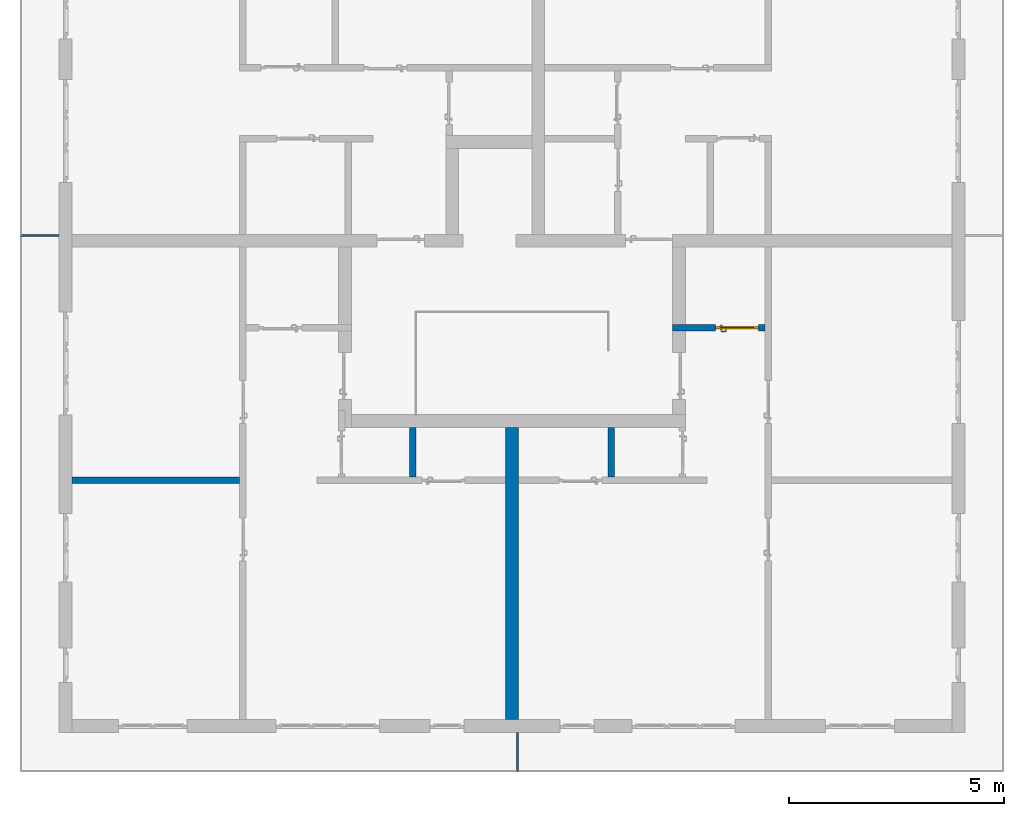
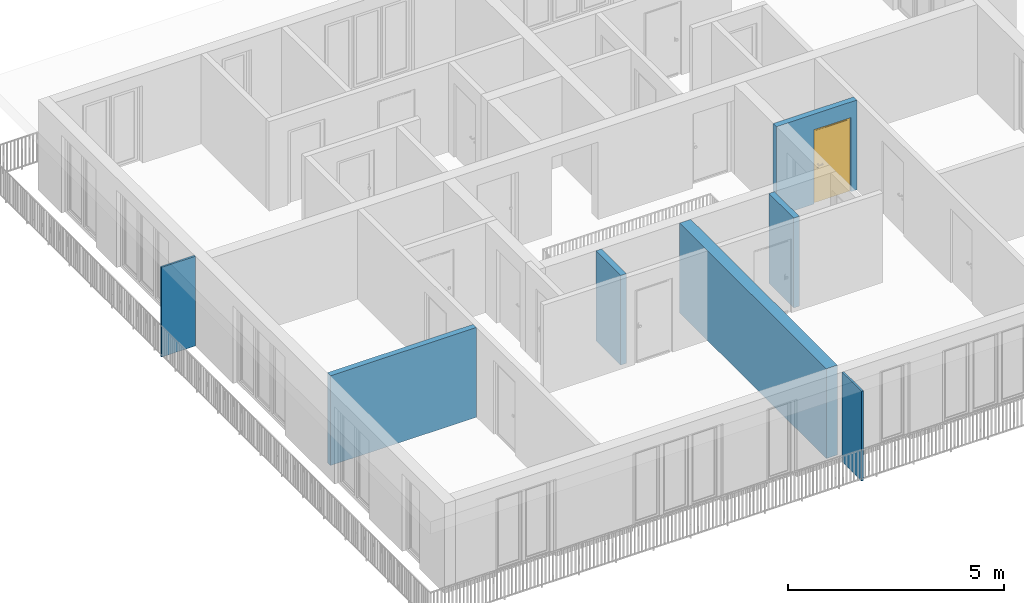
# One storey, part 7 of 54: 7 walls, 1 door, 1 opening.
"""IFC4 building model written with IfcOpenShell, lengths in metres."""

from ifc_helpers import new_model, entity, si_unit, converted_unit, derived_unit, direction, frame, origin_with_axes, place, context, subcontext, project, spatial, polygons, source, transform, mapped, material, type_object, element, fill, save


model = new_model("IFC4")

# Units and contexts
model_context = context("Model", 3, precision=1e-05, world=origin_with_axes(), true_north=direction((0.0, 1.0)))
body_context = subcontext(model_context, "Body", "Model", "MODEL_VIEW")
ifc_project = project(units=[si_unit("LENGTHUNIT", "METRE"), si_unit("AREAUNIT", "SQUARE_METRE"), si_unit("VOLUMEUNIT", "CUBIC_METRE"), converted_unit("PLANEANGLEUNIT", "DEGREE", entity("IfcPlaneAngleMeasure", 0.0174532925199), si_unit("PLANEANGLEUNIT", "RADIAN"), dimensions=[0, 0, 0, 0, 0, 0, 0]), converted_unit("TIMEUNIT", "Year", entity("IfcTimeMeasure", 31556926.0), si_unit("TIMEUNIT", "SECOND"), dimensions=[0, 0, 1, 0, 0, 0, 0]), si_unit("MASSUNIT", "GRAM", prefix="KILO"), si_unit("THERMODYNAMICTEMPERATUREUNIT", "DEGREE_CELSIUS"), si_unit("LUMINOUSINTENSITYUNIT", "LUMEN"), si_unit("ENERGYUNIT", "JOULE", prefix="MEGA"), derived_unit("THERMALCONDUCTANCEUNIT", [(si_unit("POWERUNIT", "WATT"), 1), (si_unit("LENGTHUNIT", "METRE"), -1), (si_unit("THERMODYNAMICTEMPERATUREUNIT", "KELVIN"), -1)]), derived_unit("SPECIFICHEATCAPACITYUNIT", [(si_unit("ENERGYUNIT", "JOULE"), 1), (si_unit("MASSUNIT", "GRAM", prefix="KILO"), -1), (si_unit("THERMODYNAMICTEMPERATUREUNIT", "KELVIN"), -1)]), derived_unit("MASSDENSITYUNIT", [(si_unit("MASSUNIT", "GRAM", prefix="KILO"), 1), (si_unit("VOLUMEUNIT", "CUBIC_METRE"), -1)])], contexts=[model_context])

# Site, building, storey
site_placement = place(None, origin_with_axes())
site = spatial("IfcSite", under=ifc_project, at=site_placement, CompositionType="ELEMENT")
building_placement = place(site_placement, origin_with_axes())
building = spatial("IfcBuilding", under=site, at=building_placement, CompositionType="ELEMENT")
storey_placement = place(building_placement, frame((0.0, 0.0, 9.18), z_axis=(0.0, 0.0, 1.0), x_axis=(1.0, 0.0, 0.0)))
storey = spatial("IfcBuildingStorey", under=building, at=storey_placement, Name="3. Geschoss", CompositionType="ELEMENT", Elevation=9.18)

# Walls
ifc_material_1 = material()
wall_type_1 = type_object("IfcWallType", Name="300", PredefinedType="NOTDEFINED")
wall_1_placement = place(storey_placement, frame((-1.2021993804, -2.52881223104, 0.0), z_axis=(0.0, 0.0, 1.0), x_axis=(0.0, -1.0, 0.0)))
element("IfcWall", 1, at=wall_1_placement, inside=storey, type_object=wall_type_1, material=ifc_material_1, Name="Wand-001", PredefinedType="NOTDEFINED", context=body_context, shape_type="Tessellation", body=[
    polygons([(0.3, -0.15, 0.0), (0.3, -0.15, 2.54), (0.3, 0.15, 2.54), (0.3, 0.15, 0.0), (7.1, -0.15, 0.0), (7.1, -0.15, 2.54), (7.1, 0.15, 2.54), (7.1, 0.15, 0.0)], [[[1, 2, 3, 4]], [[5, 6, 2, 1]], [[6, 7, 3, 2]], [[4, 3, 7, 8]], [[1, 4, 8, 5]], [[8, 7, 6, 5]]], closed=True),
])
wall_type_2 = type_object("IfcWallType", Name="150", PredefinedType="NOTDEFINED")
wall_2_placement = place(storey_placement, frame((-11.7421993804, -4.12881223104, 0.0), z_axis=(0.0, 0.0, 1.0), x_axis=(1.0, 0.0, 0.0)))
element("IfcWall", 2, at=wall_2_placement, inside=storey, type_object=wall_type_2, material=ifc_material_1, Name="Wand-004", PredefinedType="NOTDEFINED", context=body_context, shape_type="Tessellation", body=[
    polygons([(0.3, 0.15, 0.0), (0.3, 0.15, 2.54), (4.2, 0.15, 2.54), (4.2, 0.15, 0.0), (0.3, 0.0, 0.0), (0.3, 0.0, 2.54), (4.2, 0.0, 2.54), (4.2, 0.0, 0.0)], [[[1, 2, 3, 4]], [[5, 6, 2, 1]], [[6, 7, 3, 2]], [[4, 3, 7, 8]], [[1, 4, 8, 5]], [[8, 7, 6, 5]]], closed=True),
])
wall_3_placement = place(storey_placement, frame((-3.5921993804, -4.12881223104, 0.0), z_axis=(0.0, 0.0, 1.0), x_axis=(0.0, 1.0, 0.0)))
element("IfcWall", 3, at=wall_3_placement, inside=storey, type_object=wall_type_2, material=ifc_material_1, Name="Wand-002", PredefinedType="NOTDEFINED", context=body_context, shape_type="Tessellation", body=[
    polygons([(1.3, 0.0, 0.0), (1.3, 0.0, 2.54), (1.3, -0.15, 2.54), (1.3, -0.15, 0.0), (0.15, 0.0, 0.0), (0.15, 0.0, 2.54), (0.15, -0.15, 2.54), (0.15, -0.15, 0.0)], [[[1, 2, 3, 4]], [[5, 6, 2, 1]], [[6, 7, 3, 2]], [[4, 3, 7, 8]], [[5, 1, 4, 8]], [[8, 7, 6, 5]]], closed=True),
])
wall_4_placement = place(storey_placement, frame((1.1878006196, -4.12881223104, 0.0), z_axis=(0.0, 0.0, 1.0), x_axis=(0.0, 1.0, 0.0)))
element("IfcWall", 4, at=wall_4_placement, inside=storey, type_object=wall_type_2, material=ifc_material_1, Name="Wand-002", PredefinedType="NOTDEFINED", context=body_context, shape_type="Tessellation", body=[
    polygons([(1.3, 0.15, 0.0), (1.3, 0.15, 2.54), (1.3, 0.0, 2.54), (1.3, 0.0, 0.0), (0.15, 0.15, 0.0), (0.15, 0.15, 2.54), (0.15, 0.0, 2.54), (0.15, 0.0, 0.0)], [[[1, 2, 3, 4]], [[5, 6, 2, 1]], [[6, 7, 3, 2]], [[4, 3, 7, 8]], [[5, 1, 4, 8]], [[8, 7, 6, 5]]], closed=True),
])

# Wall, opening, door
wall_5_placement = place(storey_placement, frame((2.5378006196, -0.428812231043, 0.0), z_axis=(0.0, 0.0, 1.0), x_axis=(1.0, 0.0, 0.0)))
wall_5 = element("IfcWall", 5, at=wall_5_placement, inside=storey, type_object=wall_type_2, material=ifc_material_1, Name="Wand-002", PredefinedType="NOTDEFINED", context=body_context, shape_type="Tessellation", body=[
    polygons([(2.0, -0.05, 0.0), (2.0, -0.15, 0.0), (2.0, -0.15, 2.1), (2.0, 0.0, 2.1), (2.0, 0.0, 0.0), (2.15, 0.0, 0.0), (2.15, -0.15, 0.0), (2.15, -0.15, 2.54), (0.0, -0.15, 2.54), (0.0, -0.15, 0.0), (1.0, -0.15, 0.0), (1.0, -0.15, 2.1), (1.0, 0.0, 2.1), (1.0, 0.0, 0.0), (0.0, 0.0, 0.0), (0.0, 0.0, 2.54), (2.15, 0.0, 2.54), (1.0, -0.05, 0.0)], [[[1, 2, 3, 4, 5]], [[2, 1, 5, 6, 7]], [[3, 2, 7, 8, 9, 10, 11, 12]], [[4, 3, 12, 13]], [[6, 5, 4, 13, 14, 15, 16, 17]], [[8, 7, 6, 17]], [[17, 16, 9, 8]], [[16, 15, 10, 9]], [[18, 11, 10, 15, 14]], [[12, 11, 18, 14, 13]]], closed=True),
])
opening_placement = place(wall_5_placement, frame((1.5, 0.0, 0.0), z_axis=(0.0, 0.0, 1.0), x_axis=(1.0, 0.0, 0.0)))
opening = element("IfcOpeningElement", 6, at=opening_placement, cuts=wall_5, context=body_context, identifier="Reference", shape_type="Tessellation", body=[
    polygons([(-0.5, -0.05, 0.0), (-0.5, -0.05, 2.1), (-0.5, 0.001, 2.1), (-0.5, 0.001, 0.0), (-0.5, -0.151, 0.0), (-0.5, -0.151, 2.1), (0.5, -0.05, 2.1), (0.5, 0.001, 2.1), (0.5, -0.151, 2.1), (0.5, 0.001, 0.0), (0.5, -0.05, 0.0), (0.5, -0.151, 0.0)], [[[1, 2, 3, 4]], [[2, 1, 5, 6]], [[7, 8, 3, 2, 6, 9]], [[8, 10, 4, 3]], [[1, 4, 10, 11, 12, 5]], [[6, 5, 12, 9]], [[7, 11, 10, 8]], [[11, 7, 9, 12]]], closed=True),
])
door_type = type_object("IfcDoorType", Name="Eingang 01 1-Fl 26", OperationType="SINGLE_SWING_LEFT", PredefinedType="DOOR")
shared_shape = source(origin_with_axes(), body_context, "Body", "Tessellation", [
    polygons([(-0.5, -0.05, 0.0), (-0.5, -0.05, 2.1), (-0.5, -0.03, 2.1), (-0.5, -0.03, 0.0), (-0.4, -0.05, 0.0), (-0.4, -0.05, 2.0), (-0.1301, -0.05, 2.0), (-0.0001, -0.05, 2.0), (0.4, -0.05, 2.0), (0.4, -0.05, 0.0), (0.5, -0.05, 0.0), (0.5, -0.05, 2.1), (0.5, -0.03, 2.1), (0.5, -0.03, 0.0), (0.4, -0.03, 0.0), (0.4, -0.03, 2.0), (-0.0001, -0.03, 2.0), (-0.1301, -0.03, 2.0), (-0.4, -0.03, 2.0), (-0.4, -0.03, 0.0)], [[[1, 2, 3, 4]], [[1, 5, 6, 7, 8, 9, 10, 11, 12, 2]], [[2, 12, 13, 3]], [[4, 3, 13, 14, 15, 16, 17, 18, 19, 20]], [[5, 1, 4, 20]], [[6, 5, 20, 19]], [[7, 6, 19, 18]], [[8, 7, 18, 17]], [[9, 8, 17, 16]], [[10, 9, 16, 15]], [[11, 10, 15, 14]], [[12, 11, 14, 13]]], closed=True),
    polygons([(-0.5, -0.03, 0.0), (-0.5, -0.03, 2.1), (-0.5, 0.0, 2.1), (-0.5, 0.0, 0.0), (-0.43, -0.03, 0.0), (-0.43, -0.03, 2.03), (-0.1001, -0.03, 2.03), (-0.0301, -0.03, 2.03), (0.43, -0.03, 2.03), (0.43, -0.03, 0.0), (0.5, -0.03, 0.0), (0.5, -0.03, 2.1), (0.5, 0.0, 2.1), (0.5, 0.0, 0.0), (0.43, 0.0, 0.0), (0.43, 0.0, 2.03), (-0.0301, 0.0, 2.03), (-0.1001, 0.0, 2.03), (-0.43, 0.0, 2.03), (-0.43, 0.0, 0.0)], [[[1, 2, 3, 4]], [[1, 5, 6, 7, 8, 9, 10, 11, 12, 2]], [[2, 12, 13, 3]], [[4, 3, 13, 14, 15, 16, 17, 18, 19, 20]], [[5, 1, 4, 20]], [[6, 5, 20, 19]], [[7, 6, 19, 18]], [[8, 7, 18, 17]], [[9, 8, 17, 16]], [[10, 9, 16, 15]], [[11, 10, 15, 14]], [[12, 11, 14, 13]]], closed=True),
    polygons([(-0.43, 0.01, 0.0), (-0.43, 0.01, 2.03), (0.43, 0.01, 2.03), (0.43, 0.01, 0.0), (-0.43, -0.03, 0.0), (-0.43, -0.03, 2.03), (0.43, -0.03, 2.03), (0.43, -0.03, 0.0)], [[[1, 2, 3, 4]], [[1, 5, 6, 2]], [[2, 6, 7, 3]], [[3, 7, 8, 4]], [[4, 8, 5, 1]], [[8, 7, 6, 5]]], closed=True),
    polygons([(-0.395, -0.05, 0.0), (0.395, -0.05, 0.0), (0.395, -0.05, 0.05), (-0.395, -0.05, 0.05), (-0.395, -0.03, 0.0), (0.395, -0.03, 0.0), (0.395, -0.03, 0.07), (0.395, -0.035, 0.07), (-0.395, -0.035, 0.07), (-0.395, -0.03, 0.07)], [[[1, 2, 3, 4]], [[5, 6, 2, 1]], [[2, 6, 7, 8, 3]], [[4, 3, 8, 9]], [[1, 4, 9, 10, 5]], [[10, 7, 6, 5]], [[9, 8, 7, 10]]], closed=True),
    polygons([(0.3835, 0.02, 1.0733826859), (0.37, 0.02, 1.077), (0.37, 0.0199, 1.077), (0.3835, 0.0199, 1.0733826859), (0.393382685902, 0.02, 1.0635), (0.397, 0.02, 1.05), (0.393382685902, 0.02, 1.0365), (0.3835, 0.02, 1.0266173141), (0.37, 0.02, 1.023), (0.3565, 0.02, 1.0266173141), (0.346617314098, 0.02, 1.0365), (0.343, 0.02, 1.05), (0.346617314098, 0.02, 1.0635), (0.3565, 0.02, 1.0733826859), (0.3565, 0.0199, 1.0733826859), (0.37, 0.0101, 1.077), (0.3835, 0.0101, 1.0733826859), (0.393382685902, 0.0199, 1.0635), (0.397, 0.0199, 1.05), (0.393382685902, 0.0199, 1.0365), (0.3835, 0.0199, 1.0266173141), (0.37, 0.0199, 1.023), (0.3565, 0.0199, 1.0266173141), (0.346617314098, 0.0199, 1.0365), (0.343, 0.0199, 1.05), (0.346617314098, 0.0199, 1.0635), (0.3565, 0.0101, 1.0733826859), (0.37, 0.01, 1.077), (0.3835, 0.01, 1.0733826859), (0.393382685902, 0.0101, 1.0635), (0.397, 0.0101, 1.05), (0.393382685902, 0.0101, 1.0365), (0.3835, 0.0101, 1.0266173141), (0.37, 0.0101, 1.023), (0.3565, 0.0101, 1.0266173141), (0.346617314098, 0.0101, 1.0365), (0.343, 0.0101, 1.05), (0.346617314098, 0.0101, 1.0635), (0.3565, 0.01, 1.0733826859), (0.346617314098, 0.01, 1.0635), (0.343, 0.01, 1.05), (0.346617314098, 0.01, 1.0365), (0.3565, 0.01, 1.0266173141), (0.37, 0.01, 1.023), (0.3835, 0.01, 1.0266173141), (0.393382685902, 0.01, 1.0365), (0.397, 0.01, 1.05), (0.393382685902, 0.01, 1.0635)], [[[1, 2, 3, 4]], [[2, 1, 5, 6, 7, 8, 9, 10, 11, 12, 13, 14]], [[2, 14, 15, 3]], [[4, 3, 16, 17]], [[5, 1, 4, 18]], [[6, 5, 18, 19]], [[7, 6, 19, 20]], [[8, 7, 20, 21]], [[9, 8, 21, 22]], [[10, 9, 22, 23]], [[11, 10, 23, 24]], [[12, 11, 24, 25]], [[13, 12, 25, 26]], [[14, 13, 26, 15]], [[3, 15, 27, 16]], [[17, 16, 28, 29]], [[18, 4, 17, 30]], [[19, 18, 30, 31]], [[20, 19, 31, 32]], [[21, 20, 32, 33]], [[22, 21, 33, 34]], [[23, 22, 34, 35]], [[24, 23, 35, 36]], [[25, 24, 36, 37]], [[26, 25, 37, 38]], [[15, 26, 38, 27]], [[16, 27, 39, 28]], [[28, 39, 40, 41, 42, 43, 44, 45, 46, 47, 48, 29]], [[30, 17, 29, 48]], [[31, 30, 48, 47]], [[32, 31, 47, 46]], [[33, 32, 46, 45]], [[34, 33, 45, 44]], [[35, 34, 44, 43]], [[36, 35, 43, 42]], [[37, 36, 42, 41]], [[38, 37, 41, 40]], [[27, 38, 40, 39]]], closed=True),
    polygons([(0.362532169224, 0.019, 0.959692280177), (0.363279754556, 0.019, 0.961639806549), (0.35705, 0.019, 0.972430057958), (0.347569942042, 0.019, 0.96295), (0.365, 0.019, 0.952886751346), (0.365, 0.019, 0.9544), (0.362532169224, 0.02, 0.959692280177), (0.363279754556, 0.02, 0.961639806549), (0.364624817685, 0.02, 0.965143815798), (0.364624817685, 0.019, 0.965143815798), (0.37, 0.019, 0.967425445323), (0.37, 0.019, 0.9759), (0.357, 0.019, 0.972516660498), (0.347483339502, 0.019, 0.963), (0.365, 0.019, 0.95), (0.3441, 0.019, 0.95), (0.365, 0.019, 0.947113248654), (0.365, 0.019, 0.941339745962), (0.365, 0.019, 0.9375), (0.365, 0.02, 0.9375), (0.365, 0.02, 0.941339745962), (0.365, 0.02, 0.947113248654), (0.365, 0.02, 0.95), (0.365, 0.02, 0.952886751346), (0.365, 0.02, 0.9544), (0.346703916638, 0.02, 0.96345), (0.35655, 0.02, 0.973296083362), (0.37, 0.02, 0.9769), (0.37, 0.02, 0.967425445323), (0.375375182315, 0.019, 0.965143815798), (0.376720245444, 0.019, 0.961639806549), (0.38295, 0.019, 0.972430057958), (0.37, 0.019, 0.976), (0.357, 0.0189, 0.972516660498), (0.347483339502, 0.0189, 0.963), (0.344, 0.019, 0.95), (0.347569942042, 0.019, 0.93705), (0.35705, 0.019, 0.927569942042), (0.37, 0.019, 0.9241), (0.37, 0.019, 0.9325), (0.366464466094, 0.019, 0.933964466094), (0.366464466094, 0.02, 0.933964466094), (0.37, 0.02, 0.9231), (0.35655, 0.02, 0.926703916638), (0.37, 0.02, 0.9325), (0.346703916638, 0.02, 0.93655), (0.3431, 0.02, 0.95), (0.346617314098, 0.02, 0.9635), (0.3565, 0.02, 0.973382685902), (0.37, 0.02, 0.977), (0.375375182315, 0.02, 0.965143815798), (0.38345, 0.02, 0.973296083362), (0.376720245444, 0.02, 0.961639806549), (0.377467830776, 0.02, 0.959692280177), (0.377467830776, 0.019, 0.959692280177), (0.375, 0.019, 0.9544), (0.375, 0.019, 0.952886751346), (0.392430057958, 0.019, 0.96295), (0.383, 0.019, 0.972516660498), (0.37, 0.0189, 0.976), (0.357, 0.0101, 0.972516660498), (0.347483339502, 0.0101, 0.963), (0.344, 0.0189, 0.95), (0.347483339502, 0.019, 0.937), (0.357, 0.019, 0.927483339502), (0.37, 0.019, 0.924), (0.38295, 0.019, 0.927569942042), (0.375, 0.019, 0.941339745962), (0.375, 0.019, 0.9375), (0.373535533906, 0.019, 0.933964466094), (0.37, 0.02, 0.923), (0.3565, 0.02, 0.926617314098), (0.38345, 0.02, 0.926703916638), (0.373535533906, 0.02, 0.933964466094), (0.375, 0.02, 0.9375), (0.375, 0.02, 0.941339745962), (0.346617314098, 0.02, 0.9365), (0.343, 0.02, 0.95), (0.346617314098, 0.0199, 0.9635), (0.3565, 0.0199, 0.973382685902), (0.37, 0.0199, 0.977), (0.3835, 0.02, 0.973382685902), (0.393296083362, 0.02, 0.96345), (0.375, 0.02, 0.952886751346), (0.375, 0.02, 0.9544), (0.375, 0.02, 0.95), (0.375, 0.02, 0.947113248654), (0.375, 0.019, 0.947113248654), (0.375, 0.019, 0.95), (0.3959, 0.019, 0.95), (0.392516660498, 0.019, 0.963), (0.383, 0.0189, 0.972516660498), (0.37, 0.0101, 0.976), (0.357, 0.01, 0.972516660498), (0.347483339502, 0.01, 0.963), (0.344, 0.0101, 0.95), (0.347483339502, 0.0189, 0.937), (0.357, 0.0189, 0.927483339502), (0.37, 0.0189, 0.924), (0.383, 0.019, 0.927483339502), (0.392430057958, 0.019, 0.93705), (0.37, 0.0199, 0.923), (0.3565, 0.0199, 0.926617314098), (0.3835, 0.02, 0.926617314098), (0.393296083362, 0.02, 0.93655), (0.346617314098, 0.0199, 0.9365), (0.343, 0.0199, 0.95), (0.346617314098, 0.0101, 0.9635), (0.3565, 0.0101, 0.973382685902), (0.37, 0.0101, 0.977), (0.3835, 0.0199, 0.973382685902), (0.393382685902, 0.02, 0.9635), (0.3969, 0.02, 0.95), (0.396, 0.019, 0.95), (0.392516660498, 0.0189, 0.963), (0.383, 0.0101, 0.972516660498), (0.37, 0.01, 0.976), (0.35695, 0.01, 0.972603263039), (0.347396736961, 0.01, 0.96305), (0.344, 0.01, 0.95), (0.347483339502, 0.0101, 0.937), (0.357, 0.0101, 0.927483339502), (0.37, 0.0101, 0.924), (0.383, 0.0189, 0.927483339502), (0.392516660498, 0.019, 0.937), (0.37, 0.0101, 0.923), (0.3565, 0.0101, 0.926617314098), (0.3835, 0.0199, 0.926617314098), (0.393382685902, 0.02, 0.9365), (0.346617314098, 0.0101, 0.9365), (0.343, 0.0101, 0.95), (0.346617314098, 0.01, 0.9635), (0.3565, 0.01, 0.973382685902), (0.37, 0.01, 0.977), (0.3835, 0.0101, 0.973382685902), (0.393382685902, 0.0199, 0.9635), (0.397, 0.02, 0.95), (0.396, 0.0189, 0.95), (0.392516660498, 0.0101, 0.963), (0.383, 0.01, 0.972516660498), (0.37, 0.01, 0.9761), (0.35655, 0.01, 0.973296083362), (0.346703916638, 0.01, 0.96345), (0.3439, 0.01, 0.95), (0.347483339502, 0.01, 0.937), (0.357, 0.01, 0.927483339502), (0.37, 0.01, 0.924), (0.383, 0.0101, 0.927483339502), (0.392516660498, 0.0189, 0.937), (0.37, 0.01, 0.923), (0.3565, 0.01, 0.926617314098), (0.3835, 0.0101, 0.926617314098), (0.393382685902, 0.0199, 0.9365), (0.346617314098, 0.01, 0.9365), (0.343, 0.01, 0.95), (0.37, 0.01, 0.9769), (0.3835, 0.01, 0.973382685902), (0.393382685902, 0.0101, 0.9635), (0.397, 0.0199, 0.95), (0.396, 0.0101, 0.95), (0.392516660498, 0.01, 0.963), (0.38305, 0.01, 0.972603263039), (0.3431, 0.01, 0.95), (0.347396736961, 0.01, 0.93695), (0.35695, 0.01, 0.927396736961), (0.37, 0.01, 0.9239), (0.383, 0.01, 0.927483339502), (0.392516660498, 0.0101, 0.937), (0.37, 0.01, 0.9231), (0.35655, 0.01, 0.926703916638), (0.3835, 0.01, 0.926617314098), (0.393382685902, 0.0101, 0.9365), (0.346703916638, 0.01, 0.93655), (0.38345, 0.01, 0.973296083362), (0.393382685902, 0.01, 0.9635), (0.397, 0.0101, 0.95), (0.396, 0.01, 0.95), (0.392603263039, 0.01, 0.96305), (0.38305, 0.01, 0.927396736961), (0.392516660498, 0.01, 0.937), (0.38345, 0.01, 0.926703916638), (0.393382685902, 0.01, 0.9365), (0.393296083362, 0.01, 0.96345), (0.397, 0.01, 0.95), (0.3961, 0.01, 0.95), (0.392603263039, 0.01, 0.93695), (0.393296083362, 0.01, 0.93655), (0.3969, 0.01, 0.95)], [[[1, 2, 3, 4, 5, 6]], [[1, 7, 8, 9, 10, 2]], [[10, 11, 12, 3, 2]], [[4, 3, 13, 14]], [[15, 5, 4, 16]], [[6, 5, 15, 17, 18, 19, 20, 21, 22, 23, 24, 25]], [[6, 25, 7, 1]], [[7, 25, 24, 26, 27, 8]], [[9, 8, 27, 28, 29]], [[10, 9, 29, 11]], [[30, 31, 32, 12, 11]], [[3, 12, 33, 13]], [[14, 13, 34, 35]], [[16, 4, 14, 36]], [[17, 15, 16, 37]], [[18, 17, 37, 38]], [[38, 39, 40, 41, 19, 18]], [[19, 41, 42, 20]], [[43, 44, 21, 20, 42, 45]], [[22, 21, 44, 46]], [[23, 22, 46, 47]], [[24, 23, 47, 26]], [[48, 49, 27, 26]], [[49, 50, 28, 27]], [[51, 29, 28, 52, 53]], [[11, 29, 51, 30]], [[30, 51, 53, 54, 55, 31]], [[55, 56, 57, 58, 32, 31]], [[12, 32, 59, 33]], [[13, 33, 60, 34]], [[35, 34, 61, 62]], [[36, 14, 35, 63]], [[37, 16, 36, 64]], [[38, 37, 64, 65]], [[39, 38, 65, 66]], [[39, 67, 68, 69, 70, 40]], [[41, 40, 45, 42]], [[71, 72, 44, 43]], [[73, 43, 45, 74, 75, 76]], [[72, 77, 46, 44]], [[77, 78, 47, 46]], [[78, 48, 26, 47]], [[79, 80, 49, 48]], [[80, 81, 50, 49]], [[50, 82, 52, 28]], [[54, 53, 52, 83, 84, 85]], [[55, 54, 85, 56]], [[85, 84, 86, 87, 76, 75, 69, 68, 88, 89, 57, 56]], [[57, 89, 90, 58]], [[32, 58, 91, 59]], [[33, 59, 92, 60]], [[34, 60, 93, 61]], [[62, 61, 94, 95]], [[63, 35, 62, 96]], [[64, 36, 63, 97]], [[65, 64, 97, 98]], [[66, 65, 98, 99]], [[67, 39, 66, 100]], [[88, 68, 67, 101]], [[70, 69, 75, 74]], [[40, 70, 74, 45]], [[102, 103, 72, 71]], [[104, 71, 43, 73]], [[76, 87, 105, 73]], [[103, 106, 77, 72]], [[106, 107, 78, 77]], [[107, 79, 48, 78]], [[108, 109, 80, 79]], [[109, 110, 81, 80]], [[81, 111, 82, 50]], [[82, 112, 83, 52]], [[86, 84, 83, 113]], [[87, 86, 113, 105]], [[89, 88, 101, 90]], [[58, 90, 114, 91]], [[59, 91, 115, 92]], [[60, 92, 116, 93]], [[61, 93, 117, 94]], [[95, 94, 118, 119]], [[96, 62, 95, 120]], [[97, 63, 96, 121]], [[98, 97, 121, 122]], [[99, 98, 122, 123]], [[100, 66, 99, 124]], [[101, 67, 100, 125]], [[126, 127, 103, 102]], [[128, 102, 71, 104]], [[129, 104, 73, 105]], [[127, 130, 106, 103]], [[130, 131, 107, 106]], [[131, 108, 79, 107]], [[132, 133, 109, 108]], [[133, 134, 110, 109]], [[110, 135, 111, 81]], [[111, 136, 112, 82]], [[112, 137, 113, 83]], [[137, 129, 105, 113]], [[90, 101, 125, 114]], [[91, 114, 138, 115]], [[92, 115, 139, 116]], [[93, 116, 140, 117]], [[94, 117, 141, 118]], [[119, 118, 142, 143]], [[120, 95, 119, 144]], [[121, 96, 120, 145]], [[122, 121, 145, 146]], [[123, 122, 146, 147]], [[124, 99, 123, 148]], [[125, 100, 124, 149]], [[150, 151, 127, 126]], [[152, 126, 102, 128]], [[153, 128, 104, 129]], [[151, 154, 130, 127]], [[154, 155, 131, 130]], [[155, 132, 108, 131]], [[143, 142, 133, 132]], [[142, 156, 134, 133]], [[134, 157, 135, 110]], [[135, 158, 136, 111]], [[136, 159, 137, 112]], [[159, 153, 129, 137]], [[114, 125, 149, 138]], [[115, 138, 160, 139]], [[116, 139, 161, 140]], [[117, 140, 162, 141]], [[118, 141, 156, 142]], [[144, 119, 143, 163]], [[145, 120, 144, 164]], [[146, 145, 164, 165]], [[147, 146, 165, 166]], [[148, 123, 147, 167]], [[149, 124, 148, 168]], [[169, 170, 151, 150]], [[171, 150, 126, 152]], [[172, 152, 128, 153]], [[170, 173, 154, 151]], [[173, 163, 155, 154]], [[163, 143, 132, 155]], [[156, 174, 157, 134]], [[157, 175, 158, 135]], [[158, 176, 159, 136]], [[176, 172, 153, 159]], [[138, 149, 168, 160]], [[139, 160, 177, 161]], [[140, 161, 178, 162]], [[141, 162, 174, 156]], [[164, 144, 163, 173]], [[165, 164, 173, 170]], [[166, 165, 170, 169]], [[167, 147, 166, 179]], [[168, 148, 167, 180]], [[181, 169, 150, 171]], [[182, 171, 152, 172]], [[174, 183, 175, 157]], [[175, 184, 176, 158]], [[184, 182, 172, 176]], [[160, 168, 180, 177]], [[161, 177, 185, 178]], [[162, 178, 183, 174]], [[179, 166, 169, 181]], [[180, 167, 179, 186]], [[187, 181, 171, 182]], [[183, 188, 184, 175]], [[188, 187, 182, 184]], [[177, 180, 186, 185]], [[178, 185, 188, 183]], [[186, 179, 181, 187]], [[185, 186, 187, 188]]], closed=True),
    polygons([(0.38, 0.02, 1.05), (0.377071067812, 0.02, 1.04292893219), (0.377071067812, 0.050696439392, 1.04292893219), (0.38, 0.0509849140336, 1.05), (0.37, 0.02, 1.04), (0.37, 0.05, 1.04), (0.375518993221, 0.0584992452783, 1.04292893219), (0.378277987014, 0.0596420579258, 1.05), (0.377071067812, 0.02, 1.05707106781), (0.377071067812, 0.050696439392, 1.05707106781), (0.362928932188, 0.02, 1.04292893219), (0.362928932188, 0.049303560608, 1.04292893219), (0.368858192988, 0.0557402514855, 1.04), (0.370704557509, 0.0657045575088, 1.04292893219), (0.372816199938, 0.0678161999379, 1.05), (0.375518993221, 0.0584992452783, 1.05707106781), (0.37, 0.02, 1.06), (0.37, 0.05, 1.06), (0.36, 0.02, 1.05), (0.36, 0.0490150859664, 1.05), (0.362197392755, 0.0529812576926, 1.04292893219), (0.365606601718, 0.0606066017178, 1.04), (0.363499245278, 0.0705189932208, 1.04292893219), (0.364642057926, 0.0732779870137, 1.05), (0.370704557509, 0.0657045575088, 1.05707106781), (0.368858192988, 0.0557402514855, 1.06), (0.362928932188, 0.02, 1.05707106781), (0.362928932188, 0.049303560608, 1.05707106781), (0.359438398962, 0.0518384450452, 1.05), (0.360508645927, 0.0555086459268, 1.04292893219), (0.360740251485, 0.0638581929877, 1.04), (0.355696439392, 0.0720710678119, 1.04292893219), (0.355984914034, 0.075, 1.05), (0.363499245278, 0.0705189932208, 1.05707106781), (0.365606601718, 0.0606066017178, 1.06), (0.362197392755, 0.0529812576926, 1.05707106781), (0.358397003498, 0.0533970034977, 1.05), (0.357981257693, 0.0571973927545, 1.04292893219), (0.355, 0.065, 1.04), (0.274303560608, 0.0720710678119, 1.04292893219), (0.274015085966, 0.075, 1.05), (0.355696439392, 0.0720710678119, 1.05707106781), (0.360740251485, 0.0638581929877, 1.06), (0.360508645927, 0.0555086459268, 1.05707106781), (0.356838445045, 0.0544383989617, 1.05), (0.354303560608, 0.0579289321881, 1.04292893219), (0.275, 0.065, 1.04), (0.266500754722, 0.0705189932208, 1.04292893219), (0.265357942074, 0.0732779870137, 1.05), (0.274303560608, 0.0720710678119, 1.05707106781), (0.355, 0.065, 1.06), (0.357981257693, 0.0571973927545, 1.05707106781), (0.354015085966, 0.055, 1.05), (0.275696439392, 0.0579289321881, 1.04292893219), (0.269259748515, 0.0638581929877, 1.04), (0.259295442491, 0.0657045575088, 1.04292893219), (0.257183800062, 0.0678161999379, 1.05), (0.266500754722, 0.0705189932208, 1.05707106781), (0.275, 0.065, 1.06), (0.354303560608, 0.0579289321881, 1.05707106781), (0.275984914034, 0.055, 1.05), (0.272018742307, 0.0571973927545, 1.04292893219), (0.264393398282, 0.0606066017178, 1.04), (0.254481006779, 0.0584992452783, 1.04292893219), (0.251722012986, 0.0596420579258, 1.05), (0.259295442491, 0.0657045575088, 1.05707106781), (0.269259748515, 0.0638581929877, 1.06), (0.275696439392, 0.0579289321881, 1.05707106781), (0.273161554955, 0.0544383989617, 1.05), (0.269491354073, 0.0555086459268, 1.04292893219), (0.261141807012, 0.0557402514855, 1.04), (0.252928932188, 0.050696439392, 1.04292893219), (0.25, 0.0509849140336, 1.05), (0.254481006779, 0.0584992452783, 1.05707106781), (0.264393398282, 0.0606066017178, 1.06), (0.272018742307, 0.0571973927545, 1.05707106781), (0.271602996502, 0.0533970034977, 1.05), (0.267802607245, 0.0529812576926, 1.04292893219), (0.26, 0.05, 1.04), (0.252928932188, 0.02, 1.04292893219), (0.25, 0.02, 1.05), (0.252928932188, 0.050696439392, 1.05707106781), (0.261141807012, 0.0557402514855, 1.06), (0.269491354073, 0.0555086459268, 1.05707106781), (0.270561601038, 0.0518384450452, 1.05), (0.267071067812, 0.049303560608, 1.04292893219), (0.26, 0.02, 1.04), (0.267071067812, 0.02, 1.04292893219), (0.27, 0.02, 1.05), (0.267071067812, 0.02, 1.05707106781), (0.26, 0.02, 1.06), (0.252928932188, 0.02, 1.05707106781), (0.26, 0.05, 1.06), (0.267802607245, 0.0529812576926, 1.05707106781), (0.27, 0.0490150859664, 1.05), (0.267071067812, 0.049303560608, 1.05707106781)], [[[1, 2, 3, 4]], [[2, 5, 6, 3]], [[4, 3, 7, 8]], [[9, 1, 4, 10]], [[5, 11, 12, 6]], [[3, 6, 13, 7]], [[8, 7, 14, 15]], [[10, 4, 8, 16]], [[17, 9, 10, 18]], [[11, 19, 20, 12]], [[6, 12, 21, 13]], [[7, 13, 22, 14]], [[15, 14, 23, 24]], [[16, 8, 15, 25]], [[18, 10, 16, 26]], [[27, 17, 18, 28]], [[19, 27, 28, 20]], [[12, 20, 29, 21]], [[13, 21, 30, 22]], [[14, 22, 31, 23]], [[24, 23, 32, 33]], [[25, 15, 24, 34]], [[26, 16, 25, 35]], [[28, 18, 26, 36]], [[20, 28, 36, 29]], [[21, 29, 37, 30]], [[22, 30, 38, 31]], [[23, 31, 39, 32]], [[33, 32, 40, 41]], [[34, 24, 33, 42]], [[35, 25, 34, 43]], [[36, 26, 35, 44]], [[29, 36, 44, 37]], [[30, 37, 45, 38]], [[31, 38, 46, 39]], [[32, 39, 47, 40]], [[41, 40, 48, 49]], [[42, 33, 41, 50]], [[43, 34, 42, 51]], [[44, 35, 43, 52]], [[37, 44, 52, 45]], [[38, 45, 53, 46]], [[39, 46, 54, 47]], [[40, 47, 55, 48]], [[49, 48, 56, 57]], [[50, 41, 49, 58]], [[51, 42, 50, 59]], [[52, 43, 51, 60]], [[45, 52, 60, 53]], [[46, 53, 61, 54]], [[47, 54, 62, 55]], [[48, 55, 63, 56]], [[57, 56, 64, 65]], [[58, 49, 57, 66]], [[59, 50, 58, 67]], [[60, 51, 59, 68]], [[53, 60, 68, 61]], [[54, 61, 69, 62]], [[55, 62, 70, 63]], [[56, 63, 71, 64]], [[65, 64, 72, 73]], [[66, 57, 65, 74]], [[67, 58, 66, 75]], [[68, 59, 67, 76]], [[61, 68, 76, 69]], [[62, 69, 77, 70]], [[63, 70, 78, 71]], [[64, 71, 79, 72]], [[73, 72, 80, 81]], [[74, 65, 73, 82]], [[75, 66, 74, 83]], [[76, 67, 75, 84]], [[69, 76, 84, 77]], [[70, 77, 85, 78]], [[71, 78, 86, 79]], [[72, 79, 87, 80]], [[81, 80, 87, 88, 89, 90, 91, 92]], [[82, 73, 81, 92]], [[83, 74, 82, 93]], [[84, 75, 83, 94]], [[77, 84, 94, 85]], [[78, 85, 95, 86]], [[79, 86, 88, 87]], [[86, 95, 89, 88]], [[95, 96, 90, 89]], [[96, 93, 91, 90]], [[93, 82, 92, 91]], [[94, 83, 93, 96]], [[85, 94, 96, 95]]], closed=False),
    polygons([(0.364696699141, -0.035, 1.04469669914), (0.3625, -0.035, 1.05), (0.364696699141, -0.035, 1.05530330086), (0.37, -0.035, 1.0575), (0.375303300859, -0.035, 1.05530330086), (0.3775, -0.035, 1.05), (0.375303300859, -0.035, 1.04469669914), (0.37, -0.035, 1.0425), (0.364696699141, -0.075, 1.04469669914), (0.3625, -0.075, 1.05), (0.364696699141, -0.075, 1.05530330086), (0.37, -0.075, 1.0575), (0.375303300859, -0.075, 1.05530330086), (0.3775, -0.075, 1.05), (0.375303300859, -0.075, 1.04469669914), (0.37, -0.075, 1.0425)], [[[1, 2, 3, 4, 5, 6, 7, 8]], [[1, 9, 10, 2]], [[2, 10, 11, 3]], [[3, 11, 12, 4]], [[4, 12, 13, 5]], [[5, 13, 14, 6]], [[6, 14, 15, 7]], [[7, 15, 16, 8]], [[8, 16, 9, 1]], [[9, 16, 15, 14, 13, 12, 11, 10]]], closed=True),
    polygons([(0.395, -0.03, 0.975), (0.395, -0.035, 0.975), (0.393096988313, -0.035, 0.965432914191), (0.393096988313, -0.03, 0.965432914191), (0.395, -0.03, 1.1), (0.395, -0.035, 1.1), (0.393096988313, -0.035, 1.10956708581), (0.38767766953, -0.035, 1.11767766953), (0.379567085809, -0.035, 1.12309698831), (0.37, -0.035, 1.125), (0.360432914191, -0.035, 1.12309698831), (0.35232233047, -0.035, 1.11767766953), (0.346903011687, -0.035, 1.10956708581), (0.345, -0.035, 1.1), (0.345, -0.035, 0.975), (0.346903011687, -0.035, 0.965432914191), (0.35232233047, -0.035, 0.95732233047), (0.360432914191, -0.035, 0.951903011687), (0.37, -0.035, 0.95), (0.379567085809, -0.035, 0.951903011687), (0.38767766953, -0.035, 0.95732233047), (0.38767766953, -0.03, 0.95732233047), (0.379567085809, -0.03, 0.951903011687), (0.37, -0.03, 0.95), (0.360432914191, -0.03, 0.951903011687), (0.35232233047, -0.03, 0.95732233047), (0.346903011687, -0.03, 0.965432914191), (0.345, -0.03, 0.975), (0.345, -0.03, 1.1), (0.346903011687, -0.03, 1.10956708581), (0.35232233047, -0.03, 1.11767766953), (0.360432914191, -0.03, 1.12309698831), (0.37, -0.03, 1.125), (0.379567085809, -0.03, 1.12309698831), (0.38767766953, -0.03, 1.11767766953), (0.393096988313, -0.03, 1.10956708581)], [[[1, 2, 3, 4]], [[5, 6, 2, 1]], [[2, 6, 7, 8, 9, 10, 11, 12, 13, 14, 15, 16, 17, 18, 19, 20, 21, 3]], [[4, 3, 21, 22]], [[1, 4, 22, 23, 24, 25, 26, 27, 28, 29, 30, 31, 32, 33, 34, 35, 36, 5]], [[36, 7, 6, 5]], [[35, 8, 7, 36]], [[34, 9, 8, 35]], [[33, 10, 9, 34]], [[32, 11, 10, 33]], [[31, 12, 11, 32]], [[30, 13, 12, 31]], [[29, 14, 13, 30]], [[28, 15, 14, 29]], [[27, 16, 15, 28]], [[26, 17, 16, 27]], [[25, 18, 17, 26]], [[24, 19, 18, 25]], [[23, 20, 19, 24]], [[22, 21, 20, 23]]], closed=True),
    polygons([(0.39, -0.075, 1.08), (0.39, -0.09, 1.08), (0.395, -0.09, 1.07866025404), (0.395, -0.075, 1.07866025404), (0.35, -0.075, 1.08), (0.35, -0.09, 1.08), (0.345, -0.09, 1.07866025404), (0.341339745962, -0.09, 1.075), (0.34, -0.09, 1.07), (0.34, -0.09, 1.03), (0.341339745962, -0.09, 1.025), (0.345, -0.09, 1.02133974596), (0.35, -0.09, 1.02), (0.39, -0.09, 1.02), (0.395, -0.09, 1.02133974596), (0.398660254038, -0.09, 1.025), (0.4, -0.09, 1.03), (0.4, -0.09, 1.07), (0.398660254038, -0.09, 1.075), (0.398660254038, -0.075, 1.075), (0.4, -0.075, 1.07), (0.4, -0.075, 1.03), (0.398660254038, -0.075, 1.025), (0.395, -0.075, 1.02133974596), (0.39, -0.075, 1.02), (0.35, -0.075, 1.02), (0.345, -0.075, 1.02133974596), (0.341339745962, -0.075, 1.025), (0.34, -0.075, 1.03), (0.34, -0.075, 1.07), (0.341339745962, -0.075, 1.075), (0.345, -0.075, 1.07866025404)], [[[1, 2, 3, 4]], [[5, 6, 2, 1]], [[2, 6, 7, 8, 9, 10, 11, 12, 13, 14, 15, 16, 17, 18, 19, 3]], [[4, 3, 19, 20]], [[1, 4, 20, 21, 22, 23, 24, 25, 26, 27, 28, 29, 30, 31, 32, 5]], [[32, 7, 6, 5]], [[31, 8, 7, 32]], [[30, 9, 8, 31]], [[29, 10, 9, 30]], [[28, 11, 10, 29]], [[27, 12, 11, 28]], [[26, 13, 12, 27]], [[25, 14, 13, 26]], [[24, 15, 14, 25]], [[23, 16, 15, 24]], [[22, 17, 16, 23]], [[21, 18, 17, 22]], [[20, 19, 18, 21]]], closed=True),
])
door_placement = place(opening_placement, frame((0.4, 0.0, 0.0), z_axis=(0.0, 0.0, 1.0), x_axis=(-1.0, 0.0, 0.0)))
door = element("IfcDoor", 7, at=door_placement, inside=storey, type_object=door_type, OverallHeight=2.1, OverallWidth=1.0, PredefinedType="DOOR", context=body_context, shape_type="MappedRepresentation", body=[
    mapped(shared_shape, transform((0.4, 0.1, 0.0))),
])
fill(opening, door)

# Walls
ifc_material_2 = material()
wall_type_3 = type_object("IfcWallType", Name="50", PredefinedType="NOTDEFINED")
wall_6_placement = place(storey_placement, frame((-12.6421993804, 1.67118776896, 0.0), z_axis=(0.0, 0.0, 1.0), x_axis=(1.0, 0.0, 0.0)))
element("IfcWall", 8, at=wall_6_placement, inside=storey, type_object=wall_type_3, material=ifc_material_2, Name="Wand-003", PredefinedType="NOTDEFINED", context=body_context, shape_type="Tessellation", body=[
    polygons([(0.0, 0.0, 2.54), (0.9, 0.0, 2.54), (0.9, 0.0, 0.0), (0.0, 0.0, 0.0), (0.9, -0.05, 2.54), (0.0, -0.05, 2.54), (0.9, -0.05, 0.0), (0.0, -0.05, 0.0)], [[[1, 2, 3, 4]], [[5, 2, 1, 6]], [[2, 5, 7, 3]], [[3, 7, 8, 4]], [[6, 1, 4, 8]], [[5, 6, 8, 7]]], closed=True),
])
wall_7_placement = place(storey_placement, frame((-1.0521993804, -9.62881223104, 0.0), z_axis=(0.0, 0.0, 1.0), x_axis=(0.0, -1.0, 0.0)))
element("IfcWall", 9, at=wall_7_placement, inside=storey, type_object=wall_type_3, material=ifc_material_2, Name="Wand-003", PredefinedType="NOTDEFINED", context=body_context, shape_type="Tessellation", body=[
    polygons([(0.3, -0.05, 2.54), (0.3, 0.0, 2.54), (0.3, 0.0, 0.0), (0.3, -0.05, 0.0), (1.2, 0.0, 2.54), (1.2, -0.05, 2.54), (1.2, 0.0, 0.0), (1.2, -0.05, 0.0)], [[[1, 2, 3, 4]], [[5, 2, 1, 6]], [[2, 5, 7, 3]], [[3, 7, 8, 4]], [[6, 1, 4, 8]], [[5, 6, 8, 7]]], closed=True),
])

save(model, "model.ifc")
